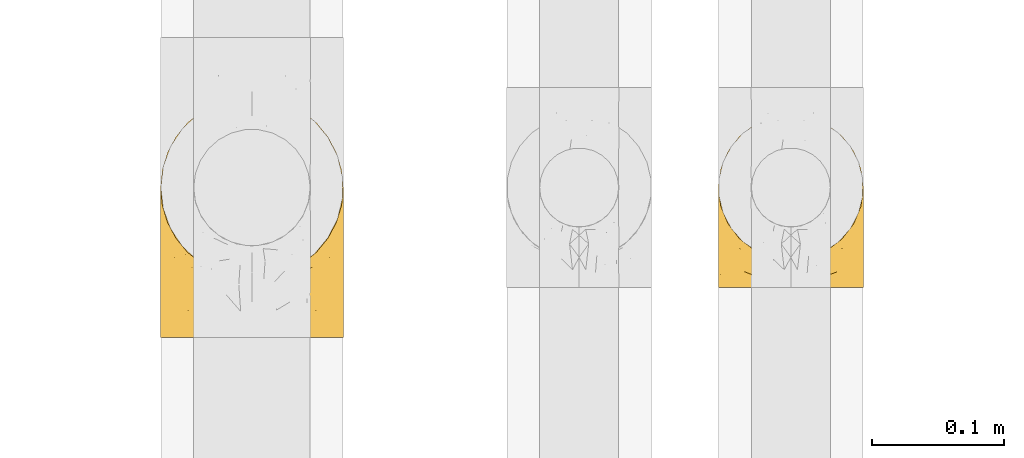
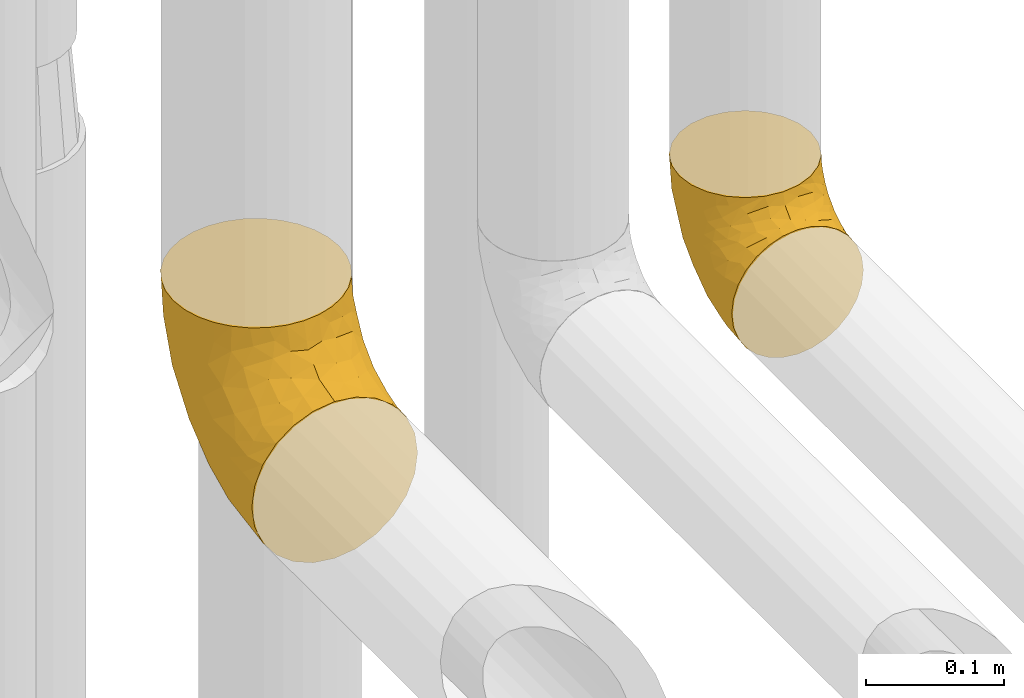
# One storey, part 190 of 827: 2 coverings.
"""IFC2X3 building model written with IfcOpenShell, lengths in millimetres."""

from ifc_helpers import new_model, entity, si_unit, converted_unit, derived_unit, direction, frame, origin, place, context, subcontext, project, spatial, faceted_brep, element, save


model = new_model("IFC2X3")

# Units and contexts
model_context = context("Model", 3, precision=0.01, world=origin(), true_north=direction((6.12303176911189e-17, 1.0)))
body_context = subcontext(model_context, "Body", "Model", "MODEL_VIEW")
ifc_project = project(units=[si_unit("LENGTHUNIT", "METRE", prefix="MILLI"), si_unit("AREAUNIT", "SQUARE_METRE"), si_unit("VOLUMEUNIT", "CUBIC_METRE"), converted_unit("PLANEANGLEUNIT", "DEGREE", entity("IfcRatioMeasure", 0.0174532925199433), si_unit("PLANEANGLEUNIT", "RADIAN"), dimensions=[0, 0, 0, 0, 0, 0, 0]), si_unit("MASSUNIT", "GRAM", prefix="KILO"), derived_unit("MASSDENSITYUNIT", [(si_unit("MASSUNIT", "GRAM", prefix="KILO"), 1), (si_unit("LENGTHUNIT", "METRE"), -3)]), derived_unit("MOMENTOFINERTIAUNIT", [(si_unit("LENGTHUNIT", "METRE"), 4)]), si_unit("TIMEUNIT", "SECOND"), si_unit("FREQUENCYUNIT", "HERTZ"), si_unit("THERMODYNAMICTEMPERATUREUNIT", "DEGREE_CELSIUS"), derived_unit("THERMALTRANSMITTANCEUNIT", [(si_unit("MASSUNIT", "GRAM", prefix="KILO"), 1), (si_unit("THERMODYNAMICTEMPERATUREUNIT", "KELVIN"), -1), (si_unit("TIMEUNIT", "SECOND"), -3)]), derived_unit("VOLUMETRICFLOWRATEUNIT", [(si_unit("LENGTHUNIT", "METRE"), 3), (si_unit("TIMEUNIT", "SECOND"), -1)]), derived_unit("MASSFLOWRATEUNIT", [(si_unit("MASSUNIT", "GRAM", prefix="KILO"), 1), (si_unit("TIMEUNIT", "SECOND"), -1)]), derived_unit("ROTATIONALFREQUENCYUNIT", [(si_unit("TIMEUNIT", "SECOND"), -1)]), si_unit("ELECTRICCURRENTUNIT", "AMPERE"), si_unit("ELECTRICVOLTAGEUNIT", "VOLT"), si_unit("POWERUNIT", "WATT"), si_unit("FORCEUNIT", "NEWTON", prefix="KILO"), si_unit("ILLUMINANCEUNIT", "LUX"), si_unit("LUMINOUSFLUXUNIT", "LUMEN"), si_unit("LUMINOUSINTENSITYUNIT", "CANDELA"), derived_unit("USERDEFINED", [(si_unit("MASSUNIT", "GRAM", prefix="KILO"), -1), (si_unit("LENGTHUNIT", "METRE"), -2), (si_unit("TIMEUNIT", "SECOND"), 3), (si_unit("LUMINOUSFLUXUNIT", "LUMEN"), 1)]), derived_unit("LINEARVELOCITYUNIT", [(si_unit("LENGTHUNIT", "METRE"), 1), (si_unit("TIMEUNIT", "SECOND"), -1)]), si_unit("PRESSUREUNIT", "PASCAL"), derived_unit("USERDEFINED", [(si_unit("LENGTHUNIT", "METRE"), -2), (si_unit("MASSUNIT", "GRAM", prefix="KILO"), 1), (si_unit("TIMEUNIT", "SECOND"), -2)]), derived_unit("LINEARFORCEUNIT", [(si_unit("MASSUNIT", "GRAM", prefix="KILO"), 1), (si_unit("LENGTHUNIT", "METRE"), 1), (si_unit("TIMEUNIT", "SECOND"), -2), (si_unit("LENGTHUNIT", "METRE"), -1)]), derived_unit("PLANARFORCEUNIT", [(si_unit("MASSUNIT", "GRAM", prefix="KILO"), 1), (si_unit("LENGTHUNIT", "METRE"), 1), (si_unit("TIMEUNIT", "SECOND"), -2), (si_unit("LENGTHUNIT", "METRE"), -2)])], contexts=[model_context])

# Site, building, storey
site_placement = place(None, origin())
site = spatial("IfcSite", under=ifc_project, at=site_placement, CompositionType="ELEMENT")
building_placement = place(site_placement, origin())
building = spatial("IfcBuilding", under=site, at=building_placement, CompositionType="ELEMENT")
storey_placement = place(building_placement, frame((0.0, 0.0, 28200.0)))
storey = spatial("IfcBuildingStorey", under=building, at=storey_placement, Name="08", CompositionType="ELEMENT", Elevation=28200.0)

# Coverings
covering_1_placement = place(storey_placement, frame((36572.9, 8729.79, 2793.26)))
element("IfcCovering", 1, at=covering_1_placement, inside=storey, Name=":ADSK_", ObjectType=":ADSK_", PredefinedType="INSULATION", context=body_context, shape_type="Brep", body=[
    faceted_brep([(2.98, 1.6, 44.47), (7.06, 1.6, 32.81), (13.63, 1.6, 22.35), (22.37, 1.6, 13.62), (32.83, 1.6, 7.05), (44.49, 1.6, 2.97), (56.75, 1.6, 1.6), (69.02, 1.6, 2.98), (80.68, 1.6, 7.06), (91.14, 1.6, 13.63), (99.87, 1.6, 22.37), (106.44, 1.6, 32.83), (110.52, 1.6, 44.49), (111.9, 1.6, 56.75), (110.94, 1.6, 65.19), (110.51, 1.6, 69.02), (108.47, 1.6, 74.85), (106.43, 1.6, 80.68), (99.86, 1.6, 91.14), (91.12, 1.6, 99.87), (80.66, 1.6, 106.44), (69.0, 1.6, 110.52), (56.75, 1.6, 111.9), (44.47, 1.6, 110.51), (32.81, 1.6, 106.43), (22.35, 1.6, 99.86), (13.62, 1.6, 91.12), (7.05, 1.6, 80.66), (5.01, 1.6, 74.83), (2.97, 1.6, 69.0), (2.55, 1.6, 65.19), (1.6, 1.6, 56.75), (95.74, 38.6, 132.75), (100.12, 44.31, 132.75), (104.51, 50.02, 132.75), (110.02, 63.32, 132.75), (110.78, 69.12, 132.75), (111.34, 73.36, 132.75), (111.9, 77.6, 132.75), (110.02, 91.87, 132.75), (104.51, 105.17, 132.75), (95.74, 116.59, 132.75), (84.32, 125.36, 132.75), (71.02, 130.87, 132.75), (56.75, 132.75, 132.75), (42.47, 130.87, 132.75), (29.17, 125.36, 132.75), (17.75, 116.59, 132.75), (8.98, 105.17, 132.75), (3.47, 91.87, 132.75), (1.6, 77.6, 132.75), (2.71, 69.12, 132.75), (3.47, 63.32, 132.75), (8.98, 50.02, 132.75), (13.37, 44.31, 132.75), (17.75, 38.6, 132.75), (29.17, 29.83, 132.75), (42.47, 24.32, 132.75), (56.75, 22.45, 132.75), (71.02, 24.32, 132.75), (84.32, 29.83, 132.75), (7.44, 98.7, 106.09), (2.99, 85.87, 106.29), (56.75, 128.28, 98.8), (46.96, 129.98, 110.62), (37.21, 117.55, 79.56), (27.14, 113.52, 82.88), (37.53, 125.49, 101.82), (24.94, 120.4, 109.51), (3.17, 53.38, 60.24), (1.6, 30.68, 62.53), (1.6, 36.84, 66.65), (1.6, 43.01, 70.77), (1.6, 49.17, 74.89), (1.6, 55.34, 79.01), (5.69, 79.67, 75.42), (12.02, 95.35, 78.6), (39.71, 103.8, 54.94), (56.75, 115.17, 67.17), (56.75, 94.33, 40.01), (15.45, 109.68, 101.35), (11.78, 25.2, 27.42), (56.75, 35.54, 6.06), (40.29, 32.54, 7.89), (9.49, 71.11, 54.81), (2.53, 24.73, 49.8), (2.41, 71.5, 83.59), (1.6, 59.45, 85.17), (1.6, 63.57, 91.33), (1.6, 67.69, 97.5), (1.6, 71.81, 103.66), (20.26, 32.94, 19.66), (15.42, 53.51, 32.92), (47.01, 123.53, 86.86), (31.45, 55.05, 19.74), (42.38, 79.98, 29.98), (44.67, 57.53, 15.6), (29.07, 24.57, 11.19), (29.36, 85.93, 42.02), (1.6, 10.61, 58.54), (1.6, 19.62, 60.33), (22.77, 53.74, 25.28), (24.08, 99.07, 62.01), (7.53, 47.38, 42.85), (6.23, 23.67, 37.14), (56.75, 67.17, 19.17), (17.33, 82.32, 51.44), (1.6, 74.01, 114.72), (1.6, 74.91, 119.22), (1.6, 75.8, 123.73), (6.73, 51.54, 115.76), (2.92, 61.55, 110.4), (3.19, 56.74, 102.67), (3.2, 63.04, 119.74), (19.32, 36.34, 125.52), (12.48, 43.61, 123.09), (14.6, 38.04, 115.24), (7.81, 51.43, 124.18), (7.5, 46.81, 108.76), (9.9, 39.79, 105.53), (45.9, 9.27, 112.2), (31.09, 16.36, 109.92), (35.08, 8.4, 108.4), (9.55, 20.7, 89.3), (3.53, 30.35, 78.37), (4.99, 17.66, 78.09), (17.56, 31.46, 110.58), (22.47, 23.73, 108.54), (31.26, 21.98, 114.9), (44.17, 22.28, 124.4), (25.83, 30.88, 124.83), (13.83, 9.8, 92.2), (20.99, 13.74, 100.98), (2.74, 16.21, 69.61), (4.52, 38.18, 87.39), (18.5, 21.3, 102.3), (2.46, 23.76, 70.27), (43.31, 17.51, 116.83), (56.75, 12.02, 114.69), (56.75, 19.65, 122.32), (8.84, 31.33, 94.21), (29.08, 26.94, 120.17), (7.16, 38.65, 96.46), (4.76, 47.33, 97.77), (3.35, 46.16, 89.34), (13.82, 29.19, 101.91), (84.41, 26.94, 120.17), (87.67, 30.88, 124.84), (110.29, 56.74, 102.67), (111.9, 67.69, 97.5), (110.57, 61.55, 110.4), (69.32, 22.28, 124.4), (111.9, 10.61, 58.54), (111.9, 19.62, 60.33), (110.14, 46.16, 89.33), (111.9, 55.34, 79.01), (111.9, 59.45, 85.17), (70.16, 17.51, 116.83), (67.57, 9.26, 112.21), (92.48, 13.74, 101.0), (82.38, 16.36, 109.94), (78.39, 8.4, 108.4), (111.9, 74.01, 114.72), (111.9, 75.8, 123.73), (111.9, 76.7, 128.24), (95.92, 31.46, 110.6), (91.0, 23.73, 108.57), (99.66, 29.19, 101.94), (94.16, 36.34, 125.53), (101.59, 43.38, 119.28), (108.5, 17.66, 78.12), (111.9, 71.81, 103.66), (110.29, 63.04, 119.74), (106.76, 51.54, 115.76), (105.99, 46.81, 108.77), (105.68, 51.43, 124.18), (108.96, 38.15, 87.39), (111.9, 49.17, 74.89), (111.9, 30.68, 62.53), (110.74, 16.19, 69.63), (99.65, 9.8, 92.22), (94.97, 21.3, 102.32), (103.92, 20.71, 89.33), (109.95, 30.35, 78.39), (103.58, 39.78, 105.54), (111.03, 23.75, 70.28), (111.9, 36.84, 66.65), (98.89, 38.04, 115.25), (104.63, 31.3, 94.22), (106.33, 38.64, 96.46), (108.72, 47.32, 97.78), (82.21, 21.97, 114.91), (111.9, 43.01, 70.77), (111.9, 63.57, 91.33), (111.08, 71.49, 83.59), (106.06, 98.7, 106.09), (105.97, 47.37, 42.86), (110.32, 53.37, 60.25), (110.96, 24.72, 49.81), (66.48, 124.11, 88.41), (110.5, 85.87, 106.29), (75.96, 125.49, 101.81), (66.4, 130.04, 110.86), (88.55, 120.4, 109.5), (98.04, 109.68, 101.34), (86.35, 113.51, 82.87), (84.14, 85.93, 42.02), (71.11, 79.98, 29.98), (73.77, 103.8, 54.94), (107.8, 79.67, 75.43), (96.17, 82.31, 51.45), (101.47, 95.34, 78.59), (104.01, 71.09, 54.82), (101.72, 25.2, 27.44), (98.08, 53.51, 32.93), (82.06, 55.07, 19.76), (93.25, 32.95, 19.67), (90.73, 53.76, 25.31), (89.43, 99.06, 62.02), (73.22, 32.56, 7.9), (84.44, 24.57, 11.2), (70.22, 57.51, 15.96), (75.29, 116.87, 77.26), (107.27, 23.67, 37.15)], [[[0, 1, 2, 3, 4, 5, 6, 7, 8, 9, 10, 11, 12, 13, 14, 15, 16, 17, 18, 19, 20, 21, 22, 23, 24, 25, 26, 27, 28, 29, 30, 31]], [[32, 33, 34, 35, 36, 37, 38, 39, 40, 41, 42, 43, 44, 45, 46, 47, 48, 49, 50, 51, 52, 53, 54, 55, 56, 57, 58, 59, 60]], [[49, 61, 62]], [[44, 63, 64]], [[65, 66, 67]], [[67, 66, 68]], [[69, 70, 71, 72, 73, 74]], [[75, 61, 76]], [[77, 78, 79]], [[61, 48, 80]], [[47, 80, 48]], [[68, 47, 46]], [[81, 2, 1]], [[82, 5, 83]], [[46, 45, 67]], [[50, 49, 62]], [[84, 75, 76]], [[85, 0, 31]], [[86, 74, 87, 88, 89, 90]], [[91, 81, 92]], [[93, 65, 67]], [[94, 95, 96]], [[47, 68, 80]], [[79, 95, 77]], [[4, 83, 5]], [[82, 83, 96]], [[97, 4, 3]], [[5, 82, 6]], [[84, 69, 75]], [[86, 69, 74]], [[98, 77, 95]], [[97, 83, 4]], [[85, 31, 99, 100, 70]], [[101, 91, 92]], [[77, 98, 102]], [[91, 3, 2]], [[103, 104, 85]], [[103, 81, 104]], [[102, 76, 80]], [[64, 93, 67]], [[97, 94, 83]], [[45, 64, 67]], [[48, 61, 49]], [[81, 91, 2]], [[96, 95, 105]], [[79, 105, 95]], [[101, 98, 94]], [[3, 91, 97]], [[94, 97, 91]], [[104, 81, 1]], [[92, 81, 103]], [[84, 92, 103]], [[106, 98, 101]], [[76, 61, 80]], [[75, 86, 62]], [[102, 80, 66]], [[84, 76, 106]], [[75, 62, 61]], [[62, 90, 107, 108, 109, 50]], [[70, 69, 85]], [[103, 85, 69]], [[94, 98, 95]], [[102, 98, 106]], [[1, 0, 104]], [[85, 104, 0]], [[67, 68, 46]], [[80, 68, 66]], [[62, 86, 90]], [[69, 86, 75]], [[76, 102, 106]], [[77, 102, 66]], [[92, 84, 106]], [[69, 84, 103]], [[44, 64, 45]], [[93, 64, 63]], [[63, 78, 93]], [[77, 93, 78]], [[93, 77, 65]], [[77, 66, 65]], [[82, 96, 105]], [[94, 96, 83]], [[101, 92, 106]], [[94, 91, 101]], [[110, 111, 112]], [[107, 90, 113]], [[114, 115, 116]], [[52, 107, 113]], [[115, 54, 117]], [[118, 119, 116]], [[120, 121, 122]], [[123, 124, 125]], [[99, 31, 30, 29, 100]], [[126, 127, 128]], [[129, 58, 57]], [[56, 114, 130]], [[131, 132, 123]], [[28, 27, 133]], [[130, 57, 56]], [[114, 56, 55]], [[134, 72, 124]], [[121, 127, 135]], [[25, 24, 132]], [[26, 131, 125]], [[26, 125, 27]], [[70, 133, 136]], [[120, 137, 121]], [[137, 138, 139]], [[126, 116, 119]], [[133, 70, 100]], [[138, 120, 22]], [[100, 28, 133]], [[123, 135, 140]], [[129, 141, 128]], [[51, 50, 109, 108, 107, 52]], [[24, 122, 132]], [[23, 122, 24]], [[53, 113, 117]], [[25, 131, 26]], [[142, 119, 143]], [[111, 89, 112]], [[112, 87, 143]], [[144, 134, 142]], [[118, 110, 112]], [[129, 137, 139]], [[128, 141, 126]], [[111, 113, 90]], [[52, 113, 53]], [[74, 73, 144]], [[145, 142, 140]], [[122, 23, 120]], [[132, 122, 121]], [[22, 120, 23]], [[137, 120, 138]], [[58, 129, 139]], [[141, 129, 57]], [[100, 29, 28]], [[27, 125, 133]], [[134, 124, 123]], [[124, 71, 136]], [[89, 88, 87, 112]], [[111, 110, 117]], [[143, 87, 144]], [[118, 116, 115]], [[112, 143, 118]], [[119, 118, 143]], [[143, 144, 142]], [[126, 119, 145]], [[127, 126, 145]], [[130, 126, 141]], [[140, 142, 134]], [[145, 119, 142]], [[135, 127, 145]], [[127, 121, 128]], [[121, 137, 128]], [[129, 128, 137]], [[73, 72, 134]], [[111, 90, 89]], [[74, 144, 87]], [[134, 123, 140]], [[135, 123, 132]], [[140, 135, 145]], [[121, 135, 132]], [[132, 131, 25]], [[125, 131, 123]], [[115, 114, 55]], [[116, 126, 130]], [[115, 117, 110]], [[115, 110, 118]], [[54, 53, 117]], [[115, 55, 54]], [[111, 117, 113]], [[116, 130, 114]], [[57, 130, 141]], [[144, 73, 134]], [[133, 125, 136]], [[124, 136, 125]], [[71, 124, 72]], [[71, 70, 136]], [[59, 146, 147]], [[148, 149, 150]], [[58, 139, 151]], [[14, 13, 152, 153, 15]], [[154, 155, 156]], [[138, 157, 139]], [[138, 158, 157]], [[159, 160, 161]], [[37, 36, 35, 162, 163, 164, 38]], [[165, 166, 167]], [[168, 169, 32]], [[60, 168, 32]], [[170, 18, 17]], [[171, 162, 172]], [[173, 174, 148]], [[169, 173, 175]], [[161, 158, 21]], [[154, 176, 177]], [[22, 21, 158]], [[178, 179, 153]], [[172, 35, 34]], [[19, 18, 180]], [[20, 19, 159]], [[167, 166, 181]], [[170, 182, 180]], [[182, 170, 183]], [[167, 184, 165]], [[185, 186, 183]], [[185, 179, 178]], [[16, 153, 179]], [[157, 151, 139]], [[187, 168, 147]], [[182, 188, 181]], [[21, 20, 161]], [[189, 154, 190]], [[180, 159, 19]], [[172, 150, 171]], [[190, 184, 189]], [[188, 167, 181]], [[190, 174, 184]], [[166, 191, 160]], [[151, 146, 59]], [[35, 172, 162]], [[175, 172, 34]], [[188, 176, 189]], [[176, 182, 183]], [[159, 161, 20]], [[158, 160, 157]], [[158, 161, 160]], [[22, 158, 138]], [[151, 157, 191]], [[58, 151, 59]], [[170, 17, 179]], [[16, 15, 153]], [[183, 170, 185]], [[192, 183, 186]], [[175, 150, 172]], [[150, 173, 148]], [[173, 169, 174]], [[154, 156, 190]], [[184, 174, 187]], [[190, 148, 174]], [[165, 184, 187]], [[189, 176, 154]], [[147, 165, 187]], [[191, 166, 165]], [[184, 167, 189]], [[188, 189, 167]], [[191, 165, 146]], [[181, 160, 159]], [[151, 191, 146]], [[157, 160, 191]], [[176, 192, 177]], [[148, 190, 156]], [[149, 148, 156, 193]], [[149, 171, 150]], [[182, 176, 188]], [[160, 181, 166]], [[181, 159, 182]], [[170, 180, 18]], [[159, 180, 182]], [[147, 168, 60]], [[169, 168, 187]], [[174, 169, 187]], [[175, 34, 33]], [[150, 175, 173]], [[32, 169, 33]], [[169, 175, 33]], [[59, 147, 60]], [[147, 146, 165]], [[192, 176, 183]], [[155, 154, 177]], [[170, 179, 185]], [[185, 178, 186]], [[179, 17, 16]], [[194, 171, 149, 193, 156, 155]], [[195, 40, 39]], [[196, 197, 198]], [[78, 63, 199]], [[197, 155, 177, 192, 186, 178]], [[200, 38, 164, 163, 162, 171]], [[201, 199, 202]], [[203, 204, 205]], [[44, 43, 202]], [[206, 207, 208]], [[194, 197, 209]], [[203, 201, 42]], [[42, 201, 43]], [[41, 203, 42]], [[210, 211, 212]], [[204, 41, 40]], [[212, 197, 196]], [[78, 208, 79]], [[198, 178, 153, 152, 13]], [[204, 195, 211]], [[13, 12, 198]], [[196, 213, 214]], [[206, 215, 207]], [[213, 10, 216]], [[204, 40, 195]], [[10, 213, 11]], [[210, 217, 206]], [[216, 10, 9]], [[210, 206, 218]], [[219, 220, 8]], [[220, 9, 8]], [[207, 105, 79]], [[221, 207, 215]], [[222, 199, 201]], [[7, 6, 82]], [[7, 82, 219]], [[209, 195, 200]], [[215, 216, 220]], [[8, 7, 219]], [[207, 79, 208]], [[221, 82, 105]], [[11, 213, 223]], [[222, 201, 205]], [[204, 211, 218]], [[221, 215, 219]], [[215, 220, 219]], [[216, 9, 220]], [[214, 213, 216]], [[223, 213, 196]], [[217, 214, 216]], [[212, 214, 210]], [[200, 195, 39]], [[211, 195, 209]], [[212, 211, 209]], [[211, 210, 218]], [[38, 200, 39]], [[200, 171, 194]], [[198, 12, 223]], [[197, 178, 198]], [[218, 208, 205]], [[210, 214, 217]], [[198, 223, 196]], [[12, 11, 223]], [[204, 203, 41]], [[201, 203, 205]], [[197, 194, 155]], [[200, 194, 209]], [[208, 218, 206]], [[218, 205, 204]], [[197, 212, 209]], [[214, 212, 196]], [[205, 208, 222]], [[78, 222, 208]], [[78, 199, 222]], [[202, 199, 63]], [[44, 202, 63]], [[201, 202, 43]], [[82, 221, 219]], [[105, 207, 221]], [[216, 215, 217]], [[206, 217, 215]]]),
])
covering_2_placement = place(storey_placement, frame((36148.99, 8691.79, 2778.95)))
element("IfcCovering", 2, at=covering_2_placement, inside=storey, Name=":ADSK_", ObjectType=":ADSK_", PredefinedType="INSULATION", context=body_context, shape_type="Brep", body=[
    faceted_brep([(128.8, 77.02, 185.05), (135.21, 89.03, 185.05), (139.16, 102.05, 185.05), (140.5, 115.6, 185.05), (139.16, 129.15, 185.05), (135.21, 142.18, 185.05), (128.79, 154.19, 185.05), (120.15, 164.71, 185.05), (109.62, 173.35, 185.05), (97.62, 179.76, 185.05), (84.59, 183.71, 185.05), (71.05, 185.05, 185.05), (57.49, 183.71, 185.05), (44.46, 179.76, 185.05), (32.45, 173.34, 185.05), (21.93, 164.7, 185.05), (13.29, 154.17, 185.05), (6.88, 142.17, 185.05), (2.93, 129.14, 185.05), (1.6, 115.6, 185.05), (2.93, 102.04, 185.05), (6.88, 89.01, 185.05), (13.3, 77.0, 185.05), (21.94, 66.48, 185.05), (32.47, 57.84, 185.05), (44.48, 51.43, 185.05), (57.5, 47.48, 185.05), (71.05, 46.15, 185.05), (84.6, 47.48, 185.05), (97.63, 51.43, 185.05), (109.64, 57.85, 185.05), (120.16, 66.49, 185.05), (71.05, 1.6, 140.5), (53.07, 1.6, 138.13), (36.32, 1.6, 131.19), (21.94, 1.6, 120.15), (10.9, 1.6, 105.77), (3.96, 1.6, 89.02), (1.6, 1.6, 71.05), (3.96, 1.6, 53.07), (10.9, 1.6, 36.32), (21.94, 1.6, 21.94), (36.32, 1.6, 10.9), (53.07, 1.6, 3.96), (71.05, 1.6, 1.6), (89.02, 1.6, 3.96), (105.77, 1.6, 10.9), (120.15, 1.6, 21.94), (131.19, 1.6, 36.32), (138.13, 1.6, 53.07), (140.5, 1.6, 71.05), (138.13, 1.6, 89.02), (131.19, 1.6, 105.77), (120.15, 1.6, 120.15), (105.77, 1.6, 131.19), (89.02, 1.6, 138.13), (111.34, 34.49, 17.68), (95.49, 45.52, 11.51), (108.88, 72.13, 27.91), (83.53, 33.03, 5.46), (71.05, 49.08, 7.85), (120.93, 152.87, 126.18), (130.29, 147.45, 149.0), (128.27, 139.93, 118.88), (135.06, 73.33, 63.74), (131.57, 50.7, 45.37), (124.15, 82.45, 48.42), (137.57, 38.79, 56.38), (139.32, 62.98, 74.21), (138.91, 120.99, 136.9), (134.46, 127.46, 118.6), (136.33, 136.13, 155.78), (96.1, 77.31, 23.09), (83.39, 67.78, 15.14), (123.38, 45.98, 31.68), (71.05, 178.79, 137.56), (89.54, 178.05, 145.0), (84.87, 167.63, 110.37), (99.87, 164.41, 115.16), (138.43, 94.09, 92.55), (132.12, 107.02, 82.51), (140.5, 93.82, 118.04), (140.5, 68.6, 92.82), (140.5, 52.71, 84.72), (140.5, 36.82, 76.62), (123.02, 159.25, 157.35), (92.69, 110.67, 41.87), (71.05, 93.32, 26.17), (71.05, 131.31, 55.33), (101.72, 173.28, 144.94), (112.9, 167.2, 149.29), (88.97, 145.55, 75.17), (140.5, 113.07, 169.09), (140.5, 110.02, 149.82), (106.45, 129.75, 67.72), (113.19, 101.31, 48.35), (120.7, 137.63, 96.05), (71.05, 160.47, 93.32), (140.5, 81.21, 105.43), (111.14, 152.64, 105.49), (140.5, 17.55, 73.57), (121.95, 115.61, 71.03), (101.12, 149.09, 87.93), (140.5, 101.92, 133.93), (97.4, 45.32, 161.32), (90.16, 32.34, 149.19), (104.91, 36.57, 144.73), (138.08, 19.07, 90.81), (138.8, 36.22, 92.55), (119.76, 22.16, 123.91), (139.57, 103.02, 168.76), (136.9, 90.46, 161.4), (108.42, 55.01, 170.11), (121.48, 64.54, 164.37), (133.72, 19.89, 102.98), (100.44, 11.1, 134.86), (104.18, 24.05, 137.08), (88.14, 17.83, 141.27), (84.22, 42.63, 164.68), (127.73, 20.99, 113.76), (116.71, 55.01, 154.22), (139.04, 88.64, 136.07), (138.49, 76.62, 122.87), (94.11, 48.77, 173.81), (117.07, 33.78, 132.07), (130.06, 62.57, 137.39), (129.3, 75.95, 168.4), (71.05, 41.99, 169.55), (71.05, 40.18, 162.77), (133.58, 77.51, 149.59), (139.33, 51.66, 96.94), (137.97, 62.34, 111.44), (134.38, 35.77, 106.66), (71.05, 32.02, 154.62), (128.49, 34.01, 117.45), (117.4, 45.86, 141.22), (129.51, 46.31, 122.95), (71.05, 23.87, 146.46), (71.05, 17.09, 144.65), (57.88, 42.63, 164.68), (4.01, 19.07, 90.81), (8.37, 19.89, 102.98), (3.39, 36.97, 93.33), (51.93, 32.34, 149.19), (14.36, 20.99, 113.76), (7.71, 35.77, 106.66), (53.95, 17.82, 141.27), (37.91, 24.05, 137.08), (33.68, 55.0, 170.11), (20.62, 64.53, 164.36), (41.65, 11.1, 134.86), (5.19, 90.44, 161.4), (1.6, 110.02, 149.82), (1.6, 101.92, 133.93), (1.6, 17.55, 73.57), (1.6, 36.82, 76.62), (22.33, 22.15, 123.91), (12.05, 62.55, 137.41), (25.4, 55.0, 154.23), (12.59, 46.29, 122.97), (24.7, 45.85, 141.24), (14.0, 33.66, 117.92), (25.03, 33.78, 132.07), (48.0, 48.76, 173.82), (1.6, 113.07, 169.09), (12.8, 75.93, 168.39), (3.05, 88.64, 136.08), (8.52, 77.49, 149.58), (4.12, 62.34, 111.45), (44.71, 45.32, 161.34), (2.52, 103.02, 168.76), (37.86, 40.01, 148.54), (1.6, 68.6, 92.82), (3.09, 51.93, 99.02), (3.6, 76.62, 122.87), (1.6, 93.82, 118.04), (1.6, 81.21, 105.43), (1.6, 52.71, 84.72), (33.22, 72.13, 27.91), (30.75, 34.49, 17.68), (18.71, 45.98, 31.68), (5.75, 136.11, 155.78), (13.81, 139.92, 118.89), (11.79, 147.43, 149.0), (21.15, 152.86, 126.18), (2.77, 62.98, 74.21), (17.94, 82.45, 48.42), (35.65, 129.75, 67.72), (21.38, 137.62, 96.06), (30.94, 152.62, 105.48), (3.66, 94.09, 92.55), (4.52, 38.79, 56.38), (40.95, 149.08, 87.93), (10.52, 50.7, 45.37), (58.59, 32.98, 5.44), (46.6, 45.52, 11.51), (58.69, 65.0, 14.08), (7.63, 127.44, 118.59), (3.18, 120.99, 136.9), (7.03, 73.33, 63.74), (46.85, 79.63, 23.84), (53.12, 145.55, 75.17), (49.4, 110.67, 41.87), (9.97, 107.02, 82.51), (19.06, 159.23, 157.35), (40.05, 175.37, 156.19), (20.14, 115.61, 71.03), (29.18, 167.19, 149.28), (42.21, 164.4, 115.14), (52.54, 178.04, 144.99), (57.21, 167.62, 110.35), (58.27, 92.37, 27.0), (28.9, 101.31, 48.35)], [[[0, 1, 2, 3, 4, 5, 6, 7, 8, 9, 10, 11, 12, 13, 14, 15, 16, 17, 18, 19, 20, 21, 22, 23, 24, 25, 26, 27, 28, 29, 30, 31]], [[32, 33, 34, 35, 36, 37, 38, 39, 40, 41, 42, 43, 44, 45, 46, 47, 48, 49, 50, 51, 52, 53, 54, 55]], [[56, 57, 58]], [[59, 44, 60]], [[46, 45, 57]], [[61, 62, 63]], [[64, 65, 66]], [[67, 64, 68]], [[69, 70, 71]], [[57, 72, 58]], [[62, 6, 5]], [[72, 57, 73]], [[74, 47, 56]], [[47, 46, 56]], [[75, 10, 76]], [[77, 76, 78]], [[48, 74, 65]], [[50, 49, 67]], [[79, 64, 80]], [[69, 81, 79]], [[68, 82, 83, 84]], [[64, 66, 80]], [[85, 62, 61]], [[86, 87, 88]], [[9, 8, 89]], [[47, 74, 48]], [[10, 9, 76]], [[85, 7, 6]], [[89, 8, 90]], [[10, 75, 11]], [[59, 73, 57]], [[45, 59, 57]], [[7, 85, 90]], [[63, 62, 70]], [[91, 86, 88]], [[68, 79, 82]], [[69, 3, 92, 93]], [[94, 86, 91]], [[86, 94, 95]], [[71, 62, 5]], [[76, 89, 78]], [[61, 63, 96]], [[88, 97, 91]], [[79, 81, 98, 82]], [[90, 8, 7]], [[99, 90, 61]], [[71, 5, 4]], [[76, 77, 75]], [[58, 95, 66]], [[79, 70, 69]], [[67, 65, 64]], [[77, 91, 97]], [[61, 96, 99]], [[4, 3, 69]], [[70, 62, 71]], [[67, 84, 100, 50]], [[79, 68, 64]], [[84, 67, 68]], [[65, 49, 48]], [[65, 67, 49]], [[66, 65, 74]], [[58, 66, 74]], [[66, 101, 80]], [[99, 102, 78]], [[95, 101, 66]], [[62, 85, 6]], [[90, 85, 61]], [[80, 101, 96]], [[70, 79, 80]], [[86, 95, 58]], [[94, 101, 95]], [[4, 69, 71]], [[69, 93, 103, 81]], [[57, 56, 46]], [[74, 56, 58]], [[77, 78, 102]], [[75, 77, 97]], [[80, 63, 70]], [[63, 80, 96]], [[101, 94, 96]], [[94, 102, 99]], [[94, 99, 96]], [[90, 99, 78]], [[94, 91, 102]], [[77, 102, 91]], [[9, 89, 76]], [[90, 78, 89]], [[44, 59, 45]], [[73, 59, 60]], [[60, 87, 73]], [[86, 73, 87]], [[73, 86, 72]], [[86, 58, 72]], [[104, 105, 106]], [[100, 84, 107]], [[84, 83, 108]], [[51, 100, 107]], [[54, 53, 109]], [[52, 51, 107]], [[110, 111, 93]], [[30, 29, 112]], [[113, 31, 30]], [[53, 52, 114]], [[54, 115, 55]], [[109, 116, 115]], [[115, 117, 55]], [[118, 105, 104]], [[119, 53, 114]], [[104, 106, 120]], [[121, 122, 81]], [[120, 113, 112]], [[112, 113, 30]], [[123, 112, 29]], [[1, 0, 111]], [[124, 106, 116]], [[113, 120, 125]], [[110, 93, 92]], [[3, 2, 92]], [[121, 81, 103]], [[124, 116, 109]], [[0, 126, 111]], [[51, 50, 100]], [[28, 27, 127]], [[127, 128, 118]], [[110, 92, 2]], [[113, 125, 129]], [[126, 113, 129]], [[31, 126, 0]], [[129, 125, 122]], [[123, 29, 28]], [[130, 131, 132]], [[118, 133, 105]], [[103, 93, 111]], [[127, 118, 28]], [[132, 134, 119]], [[118, 104, 123]], [[32, 55, 117]], [[106, 105, 116]], [[113, 126, 31]], [[111, 126, 129]], [[2, 1, 110]], [[111, 110, 1]], [[118, 123, 28]], [[112, 123, 104]], [[104, 120, 112]], [[120, 135, 125]], [[136, 125, 135]], [[82, 98, 131]], [[136, 135, 124]], [[131, 98, 122]], [[131, 125, 136]], [[98, 81, 122]], [[132, 131, 136]], [[121, 111, 129]], [[125, 131, 122]], [[105, 137, 117]], [[138, 32, 117, 137]], [[111, 121, 103]], [[122, 121, 129]], [[132, 114, 108]], [[114, 52, 107]], [[108, 114, 107]], [[108, 83, 130]], [[114, 132, 119]], [[84, 108, 107]], [[83, 82, 130]], [[131, 130, 82]], [[132, 108, 130]], [[134, 132, 136]], [[53, 119, 109]], [[124, 134, 136]], [[109, 119, 134]], [[109, 115, 54]], [[117, 115, 116]], [[105, 117, 116]], [[124, 109, 134]], [[106, 124, 135]], [[133, 118, 128]], [[133, 137, 105]], [[106, 135, 120]], [[139, 133, 128]], [[140, 141, 142]], [[143, 133, 139]], [[26, 139, 127]], [[141, 144, 145]], [[146, 143, 147]], [[148, 24, 149]], [[150, 34, 33]], [[143, 146, 137]], [[151, 152, 153]], [[36, 140, 37]], [[38, 37, 154]], [[154, 140, 155]], [[144, 35, 156]], [[35, 34, 156]], [[149, 157, 158]], [[157, 159, 160]], [[161, 162, 159]], [[26, 127, 27]], [[128, 127, 139]], [[163, 26, 25]], [[20, 19, 164]], [[140, 154, 37]], [[165, 149, 23]], [[22, 165, 23]], [[160, 158, 157]], [[23, 149, 24]], [[148, 25, 24]], [[151, 153, 166]], [[21, 151, 22]], [[151, 167, 165]], [[159, 168, 145]], [[34, 150, 156]], [[158, 169, 148]], [[164, 152, 170]], [[20, 164, 170]], [[170, 151, 21]], [[147, 143, 171]], [[163, 148, 169]], [[26, 163, 139]], [[162, 156, 147]], [[158, 148, 149]], [[139, 169, 143]], [[171, 143, 169]], [[150, 146, 147]], [[151, 165, 22]], [[149, 165, 167]], [[151, 170, 152]], [[21, 20, 170]], [[148, 163, 25]], [[139, 163, 169]], [[157, 149, 167]], [[158, 160, 171]], [[168, 172, 173]], [[174, 175, 176]], [[176, 168, 174]], [[145, 144, 161]], [[166, 174, 167]], [[172, 168, 176]], [[157, 168, 159]], [[168, 157, 174]], [[167, 174, 157]], [[32, 138, 137, 146]], [[166, 153, 175]], [[174, 166, 175]], [[151, 166, 167]], [[36, 141, 140]], [[177, 142, 173]], [[35, 141, 36]], [[140, 142, 155]], [[142, 141, 145]], [[173, 142, 145]], [[142, 177, 155]], [[168, 173, 145]], [[177, 173, 172]], [[35, 144, 141]], [[161, 144, 156]], [[162, 161, 156]], [[145, 161, 159]], [[33, 32, 146]], [[156, 150, 147]], [[33, 146, 150]], [[171, 162, 147]], [[159, 162, 160]], [[143, 137, 133]], [[158, 171, 169]], [[171, 160, 162]], [[178, 179, 180]], [[17, 181, 18]], [[182, 183, 184]], [[185, 155, 177, 172]], [[180, 186, 178]], [[187, 188, 189]], [[190, 172, 176, 175]], [[191, 38, 154, 155]], [[189, 192, 187]], [[39, 191, 193]], [[44, 43, 194]], [[40, 39, 193]], [[195, 196, 194]], [[179, 195, 42]], [[43, 42, 195]], [[40, 180, 41]], [[183, 182, 197]], [[181, 198, 18]], [[42, 41, 179]], [[185, 191, 155]], [[185, 190, 199]], [[200, 195, 178]], [[201, 88, 202]], [[190, 203, 199]], [[19, 18, 198]], [[181, 17, 183]], [[16, 15, 204]], [[14, 13, 205]], [[203, 206, 186]], [[183, 16, 204]], [[189, 207, 208]], [[204, 207, 184]], [[208, 209, 210]], [[88, 201, 97]], [[13, 209, 205]], [[200, 196, 195]], [[208, 207, 205]], [[12, 75, 209]], [[11, 75, 12]], [[211, 88, 87]], [[87, 60, 196]], [[12, 209, 13]], [[210, 75, 97]], [[14, 207, 15]], [[198, 175, 153, 152]], [[198, 190, 175]], [[212, 178, 186]], [[16, 183, 17]], [[180, 193, 186]], [[187, 201, 202]], [[201, 192, 210]], [[183, 197, 181]], [[198, 181, 197]], [[190, 185, 172]], [[191, 185, 199]], [[191, 199, 193]], [[191, 39, 38]], [[199, 203, 186]], [[40, 193, 180]], [[199, 186, 193]], [[186, 206, 212]], [[212, 202, 178]], [[203, 188, 206]], [[207, 204, 15]], [[183, 204, 184]], [[190, 197, 203]], [[182, 203, 197]], [[206, 187, 212]], [[202, 212, 187]], [[190, 198, 197]], [[198, 152, 164, 19]], [[180, 179, 41]], [[195, 179, 178]], [[75, 210, 209]], [[201, 210, 97]], [[188, 182, 184]], [[182, 188, 203]], [[189, 188, 184]], [[187, 206, 188]], [[207, 189, 184]], [[189, 208, 192]], [[210, 192, 208]], [[201, 187, 192]], [[208, 205, 209]], [[14, 205, 207]], [[178, 202, 200]], [[196, 211, 87]], [[196, 200, 211]], [[194, 196, 60]], [[44, 194, 60]], [[195, 194, 43]], [[200, 202, 211]], [[88, 211, 202]]]),
])

save(model, "model.ifc")
